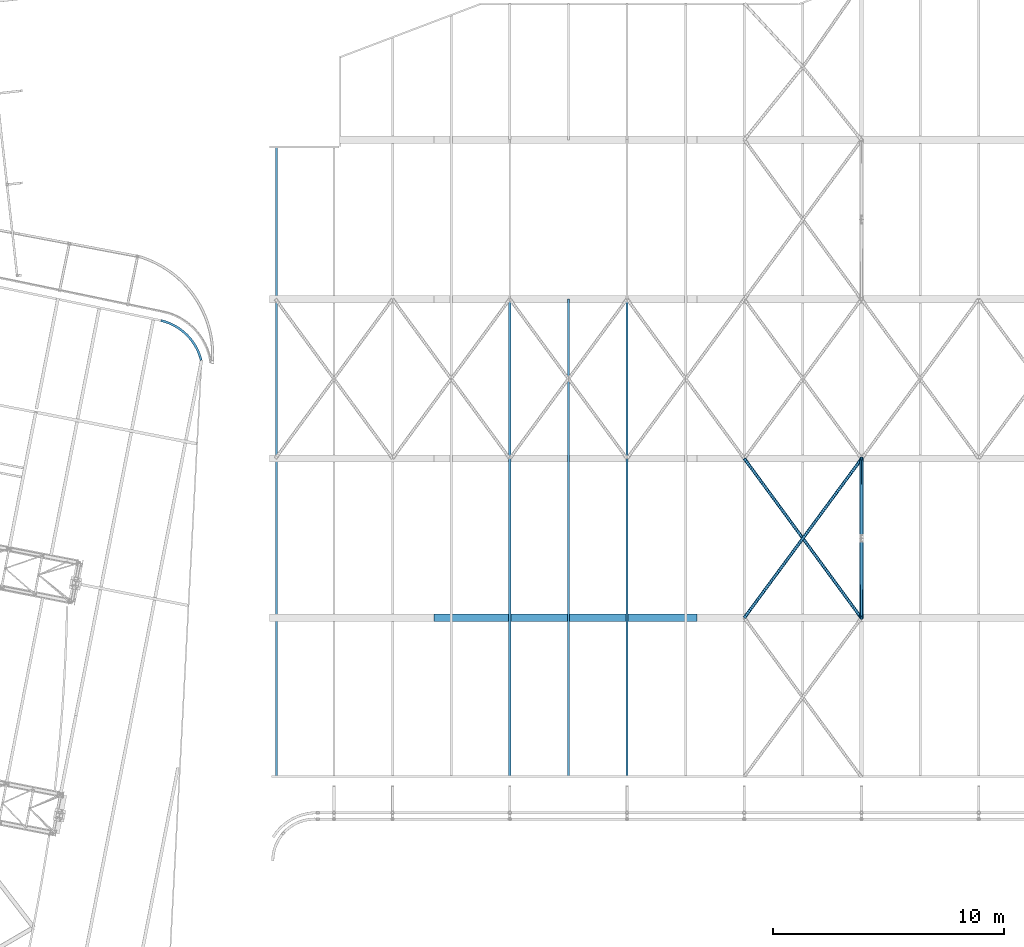
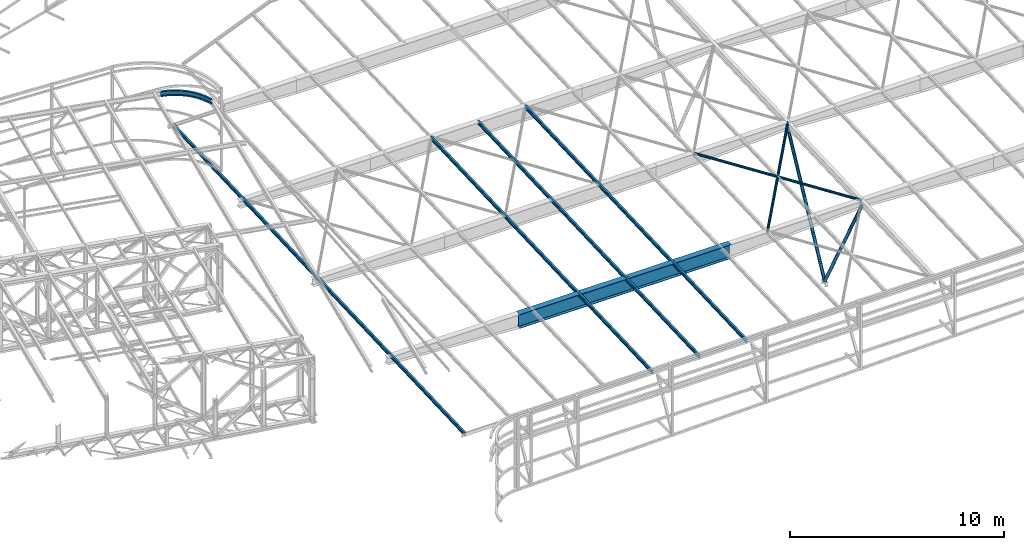
# One storey, part 112 of 215: 8 beams, 2 members, 10 elements without a shape of their own.
"""IFC2X3 building model written with IfcOpenShell, lengths in millimetres."""

from ifc_helpers import new_model, entity, si_unit, frame, origin_with_axes, origin_2d_with_axis, place, context, subcontext, project, spatial, hollow_circle, i_section, extrude, clip, halfspace, material, type_object, element, aggregate, save


model = new_model("IFC2X3")

# Units and contexts
model_context = context("Model", 3, precision=1e-05, world=origin_with_axes())
body_context = subcontext(model_context, "Body", "Model", "MODEL_VIEW")
ifc_project = project(units=[si_unit("LENGTHUNIT", "METRE", prefix="MILLI"), si_unit("AREAUNIT", "SQUARE_METRE"), si_unit("VOLUMEUNIT", "CUBIC_METRE"), si_unit("MASSUNIT", "GRAM", prefix="KILO"), si_unit("TIMEUNIT", "SECOND"), si_unit("PLANEANGLEUNIT", "RADIAN"), si_unit("SOLIDANGLEUNIT", "STERADIAN"), si_unit("THERMODYNAMICTEMPERATUREUNIT", "DEGREE_CELSIUS"), si_unit("LUMINOUSINTENSITYUNIT", "LUMEN")], contexts=[model_context])

# Site, building, storey
site_placement = place(None, origin_with_axes())
site = spatial("IfcSite", under=ifc_project, at=site_placement, CompositionType="ELEMENT")
building_placement = place(site_placement, origin_with_axes())
building = spatial("IfcBuilding", under=site, at=building_placement, Name="Undefined", CompositionType="ELEMENT")
storey_placement = place(building_placement, origin_with_axes())
storey = spatial("IfcBuildingStorey", under=building, at=storey_placement, Name="Undefined", CompositionType="ELEMENT", Elevation=0.0)

# Assembly, beam
assembly_1_placement = place(storey_placement, origin_with_axes())
assembly_1 = element("IfcElementAssembly", 1, at=assembly_1_placement, inside=storey, Name="Steel Assembly", AssemblyPlace="NOTDEFINED", PredefinedType="RIGID_FRAME")
ifc_material_1 = material(Name="STEEL/S275JR")
beam_type_1 = type_object("IfcBeamType", Name="IPE200", PredefinedType="NOTDEFINED")
beam_1_placement = place(assembly_1_placement, frame((119365.009188289, 34986.5208587885, 2830.37468376456), z_axis=(0.0, -0.0399624260079826, 0.999201183199638), x_axis=(0.0, 0.999201183199638, 0.0399624260079844)))
beam_1 = element("IfcBeam", 2, at=beam_1_placement, type_object=beam_type_1, material=ifc_material_1, ObjectType="IPE200", context=body_context, shape_type="SweptSolid", body=[
    extrude(i_section(OverallWidth=100.0, OverallDepth=200.0, WebThickness=5.599999905, FlangeThickness=8.5, FilletRadius=12.0, at=origin_2d_with_axis()), frame((20709.2363920804, 0.0, 1.4369919415558e-13), z_axis=(-1.0, 0.0, 0.0), x_axis=(-6.93889390390723e-18, -1.0, -3.46944695195361e-18)), (0.0, 0.0, 1.0), 20709.2),
])
aggregate(assembly_1, [beam_1])

assembly_2_placement = place(storey_placement, origin_with_axes())
assembly_2 = element("IfcElementAssembly", 3, at=assembly_2_placement, inside=storey, Name="Steel Assembly", AssemblyPlace="NOTDEFINED", PredefinedType="RIGID_FRAME")
beam_2_placement = place(assembly_2_placement, frame((116825.009434393, 34986.5208587878, 2830.37468377879), z_axis=(0.0, -0.0399624260079826, 0.999201183199638), x_axis=(0.0, 0.999201183199638, 0.0399624260079844)))
beam_2 = element("IfcBeam", 4, at=beam_2_placement, type_object=beam_type_1, material=ifc_material_1, ObjectType="IPE200", context=body_context, shape_type="SweptSolid", body=[
    extrude(i_section(OverallWidth=100.0, OverallDepth=200.0, WebThickness=5.599999905, FlangeThickness=8.5, FilletRadius=12.0, at=origin_2d_with_axis()), frame((20713.0754449788, 0.0, 0.0), z_axis=(-1.0, 0.0, 0.0), x_axis=(-6.93889390390723e-18, -1.0, -3.46944695195361e-18)), (0.0, 0.0, 1.0), 20713.1),
])
aggregate(assembly_2, [beam_2])

assembly_3_placement = place(storey_placement, origin_with_axes())
assembly_3 = element("IfcElementAssembly", 5, at=assembly_3_placement, inside=storey, Name="Steel Assembly", AssemblyPlace="NOTDEFINED", PredefinedType="RIGID_FRAME")
beam_3_placement = place(assembly_3_placement, frame((114285.009680497, 34986.520858787, 2830.37468379303), z_axis=(0.0, -0.0399624260079826, 0.999201183199638), x_axis=(0.0, 0.999201183199638, 0.0399624260079844)))
beam_3 = element("IfcBeam", 6, at=beam_3_placement, type_object=beam_type_1, material=ifc_material_1, ObjectType="IPE200", context=body_context, shape_type="SweptSolid", body=[
    extrude(i_section(OverallWidth=100.0, OverallDepth=200.0, WebThickness=5.599999905, FlangeThickness=8.5, FilletRadius=12.0, at=origin_2d_with_axis()), frame((20709.2363920804, 0.0, 1.4369919415558e-13), z_axis=(-1.0, 0.0, 0.0), x_axis=(-6.93889390390723e-18, -1.0, -3.46944695195361e-18)), (0.0, 0.0, 1.0), 20709.2),
])
aggregate(assembly_3, [beam_3])

assembly_4_placement = place(storey_placement, origin_with_axes())
assembly_4 = element("IfcElementAssembly", 7, at=assembly_4_placement, inside=storey, Name="Steel Assembly", AssemblyPlace="NOTDEFINED", PredefinedType="RIGID_FRAME")
beam_4_placement = place(assembly_4_placement, frame((104175.010665098, 34986.5208587848, 2830.37468389512), z_axis=(0.0, -0.0399624260079826, 0.999201183199638), x_axis=(0.0, 0.999201183199638, 0.0399624260079844)))
beam_4 = element("IfcBeam", 8, at=beam_4_placement, type_object=beam_type_1, material=ifc_material_1, ObjectType="IPE200", context=body_context, shape_type="SweptSolid", body=[
    extrude(i_section(OverallWidth=100.0, OverallDepth=200.0, WebThickness=5.599999905, FlangeThickness=8.5, FilletRadius=12.0, at=origin_2d_with_axis()), frame((27339.3286040039, 0.0, 0.0), z_axis=(-1.0, 0.0, 0.0), x_axis=(-6.93889390390723e-18, -1.0, -3.46944695195361e-18)), (0.0, 0.0, 1.0), 27339.3),
])
aggregate(assembly_4, [beam_4])

assembly_5_placement = place(storey_placement, origin_with_axes())
assembly_5 = element("IfcElementAssembly", 9, at=assembly_5_placement, inside=storey, Name="Steel Assembly", AssemblyPlace="NOTDEFINED", PredefinedType="RIGID_FRAME")
ifc_material_2 = material(Name="STEEL/S235JR")
beam_type_2 = type_object("IfcBeamType", PredefinedType="NOTDEFINED")
beam_5_placement = place(assembly_5_placement, frame((129525.007485112, 41848.5726511471, 3134.99214492766), z_axis=(-2.1980000026525e-06, -0.0399625230126959, 0.999201179317573), x_axis=(-0.591317297898593, 0.805794849861813, 0.0322259699944735)))
beam_5 = element("IfcBeam", 10, at=beam_5_placement, type_object=beam_type_2, material=ifc_material_2, context=body_context, shape_type="SweptSolid", body=[
    extrude(hollow_circle(Radius=69.84999845, WallThickness=8.0, at=origin_2d_with_axis()), frame((8590.98601613036, 3.26934236157088e-13, 2.86985615939111e-13), z_axis=(-1.0, 0.0, 0.0), x_axis=(-6.93889390390723e-18, -1.0, -3.46944695195361e-18)), (0.0, 0.0, 1.0), 8591.0),
])
aggregate(assembly_5, [beam_5])

assembly_6_placement = place(storey_placement, origin_with_axes())
assembly_6 = element("IfcElementAssembly", 11, at=assembly_6_placement, inside=storey, Name="Steel Assembly", AssemblyPlace="NOTDEFINED", PredefinedType="RIGID_FRAME")
beam_6_placement = place(assembly_6_placement, frame((124445.008846603, 41864.3060592653, 3135.6103045761), z_axis=(-2.1980000026525e-06, -0.0399625230126959, 0.999201179317573), x_axis=(0.593069181044462, 0.804508285060313, 0.0321771000024123)))
beam_6 = element("IfcBeam", 12, at=beam_6_placement, type_object=beam_type_2, material=ifc_material_2, context=body_context, shape_type="SweptSolid", body=[
    extrude(hollow_circle(Radius=69.84999845, WallThickness=8.0, at=origin_2d_with_axis()), frame((8565.60886410277, -1.57137003809309e-11, 0.0), z_axis=(-1.0, 0.0, 0.0), x_axis=(-6.93889390390723e-18, -1.0, -3.46944695195361e-18)), (0.0, 0.0, 1.0), 8565.6),
])
aggregate(assembly_6, [beam_6])

assembly_7_placement = place(storey_placement, origin_with_axes())
assembly_7 = element("IfcElementAssembly", 13, at=assembly_7_placement, inside=storey, Name="Steel Assembly", AssemblyPlace="NOTDEFINED", PredefinedType="RIGID_FRAME")
ifc_material_3 = material(Name="STEEL/S355JR")
beam_type_3 = type_object("IfcBeamType", PredefinedType="NOTDEFINED")
beam_7_placement = place(assembly_7_placement, frame((110996.242112218, 41861.7757501749, 2798.87695981196), z_axis=(0.0, 0.0, -1.0), x_axis=(1.0, 0.0, 0.0)))
beam_7 = element("IfcBeam", 14, at=beam_7_placement, type_object=beam_type_3, material=ifc_material_3, Name="POUTRE", context=body_context, shape_type="SweptSolid", body=[
    extrude(i_section(OverallWidth=320.0, OverallDepth=800.0, WebThickness=6.0, FlangeThickness=20.0, FilletRadius=4.2, at=origin_2d_with_axis()), frame((11406.6037240309, 0.0, 0.0), z_axis=(-1.0, 0.0, 0.0), x_axis=(-6.93889390390723e-18, -1.0, -3.46944695195361e-18)), (0.0, 0.0, 1.0), 11406.6),
])
aggregate(assembly_7, [beam_7])

assembly_8_placement = place(storey_placement, origin_with_axes())
assembly_8 = element("IfcElementAssembly", 15, at=assembly_8_placement, inside=storey, Name="Steel Assembly", AssemblyPlace="NOTDEFINED", PredefinedType="RIGID_FRAME")
beam_type_4 = type_object("IfcBeamType", Name="UPE300", PredefinedType="NOTDEFINED")
beam_8_placement = place(assembly_8_placement, frame((100906.761782936, 53030.3947720718, 12005.6851008436), z_axis=(-0.00387977699982433, 0.00382455199983033, -0.999985159956103), x_axis=(-0.712146511133444, 0.702009734131542, 0.00544792300102057)))
beam_8 = element("IfcBeam", 16, at=beam_8_placement, type_object=beam_type_4, material=ifc_material_1, Name="POUTRE", ObjectType="UPE300", context=body_context, shape_type="SweptSolid", body=[
    entity("IfcRevolvedAreaSolid", entity("IfcUShapeProfileDef", "AREA", None, entity("IfcAxis2Placement2D", entity("IfcCartesianPoint", [0.0, 0.0]), entity("IfcDirection", [1.0, 0.0])), 300.0, 100.0, 9.5, 15.0, 15.0), entity("IfcAxis2Placement3D", entity("IfcCartesianPoint", [2450.60057510093, 2.8959728570392e-11, 1.82111496071979e-12]), entity("IfcDirection", [-0.85330971805965, 0.521404377681048, -3.25411273207284e-19]), entity("IfcDirection", [-0.521404377681049, -0.85330971805965, -1.13095547608767e-18])), entity("IfcAxis1Placement", entity("IfcCartesianPoint", [2350.0, 0.0, 0.0]), entity("IfcDirection", [0.0, 1.0, 0.0])), 1.09699185072595),
])
aggregate(assembly_8, [beam_8])

# Assembly, member
assembly_9_placement = place(storey_placement, origin_with_axes())
assembly_9 = element("IfcElementAssembly", 17, at=assembly_9_placement, inside=storey, Name="Steel Assembly", AssemblyPlace="NOTDEFINED", PredefinedType="RIGID_FRAME")
member_type = type_object("IfcMemberType", PredefinedType="NOTDEFINED")
member_1_placement = place(assembly_9_placement, frame((129525.008205612, 48768.6074132622, 3081.22899316271), z_axis=(-1.0, 0.0, 0.0), x_axis=(0.0, -0.460804893836069, -0.887501464684273)))
member_1 = element("IfcMember", 18, at=member_1_placement, type_object=member_type, material=ifc_material_1, Name="POUTRE", context=body_context, shape_type="Clipping", body=[
    clip(clip(extrude(hollow_circle(Radius=84.15000155, WallThickness=10.0, at=origin_2d_with_axis()), frame((7562.3224673631, 0.0, 0.0), z_axis=(-1.0, 0.0, 0.0), x_axis=(-6.93889390390723e-18, -1.0, -3.46944695195361e-18)), (0.0, 0.0, 1.0), 7562.3), halfspace(frame((7538.0183449263, 84.1500015499987, 84.150001550006), z_axis=(0.887501464684264, -0.460804893836085, 0.0), x_axis=(0.0, 0.0, -1.0)), False)), halfspace(frame((7274.41564342925, 110.318815323044, 2.03435774892569e-08), z_axis=(0.460804893836073, 0.88750146468427, 0.0), x_axis=(0.0, 0.0, -1.0)), False)),
])
aggregate(assembly_9, [member_1])

assembly_10_placement = place(storey_placement, origin_with_axes())
assembly_10 = element("IfcElementAssembly", 19, at=assembly_10_placement, inside=storey, Name="Steel Assembly", AssemblyPlace="NOTDEFINED", PredefinedType="RIGID_FRAME")
member_2_placement = place(assembly_10_placement, frame((129525.008205612, 41861.7721982151, 2804.95705097285), z_axis=(-1.0, 0.0, 0.0), x_axis=(0.0, 0.476317523843881, -0.879273345711807)))
member_2 = element("IfcMember", 20, at=member_2_placement, type_object=member_type, material=ifc_material_1, Name="POUTRE", context=body_context, shape_type="Clipping", body=[
    clip(clip(extrude(hollow_circle(Radius=84.15000155, WallThickness=10.0, at=origin_2d_with_axis()), frame((7318.41545425828, 0.0, 0.0), z_axis=(-1.0, 0.0, 0.0), x_axis=(-6.93889390390723e-18, -1.0, -3.46944695195361e-18)), (0.0, 0.0, 1.0), 7318.4), halfspace(frame((7295.83786301986, -84.1500015499987, -84.150001550006), z_axis=(0.879273345711824, 0.476317523843849, 0.0), x_axis=(0.0, 0.0, 1.0)), False)), halfspace(frame((7030.81052661851, -111.390293358796, 2.03435774892569e-08), z_axis=(-0.476317523843881, 0.879273345711807, 0.0), x_axis=(0.0, 0.0, -1.0)), True)),
])
aggregate(assembly_10, [member_2])

save(model, "model.ifc")
